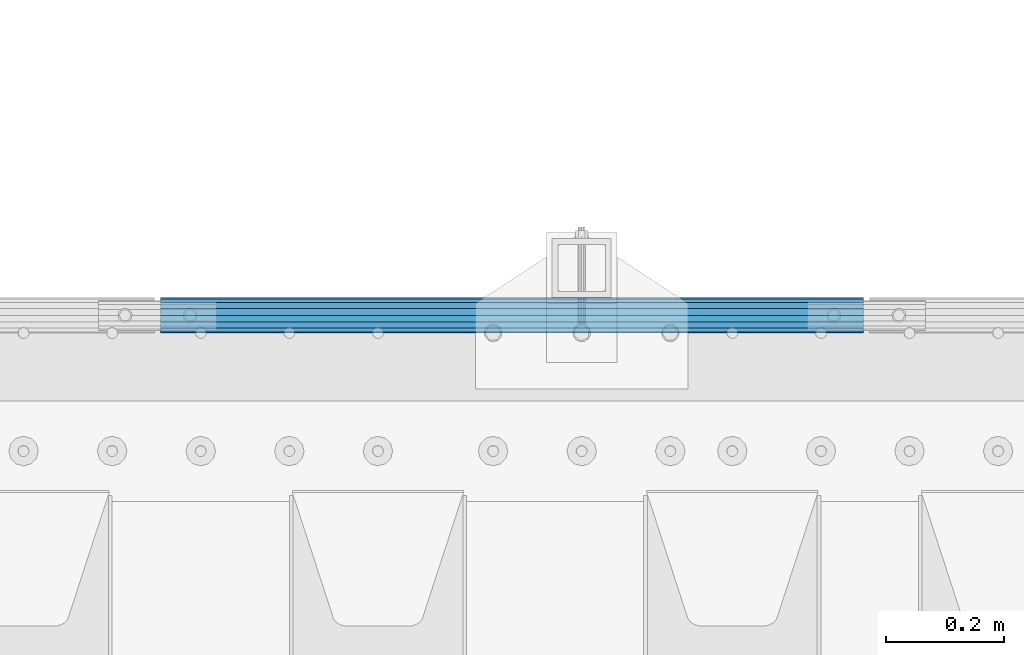
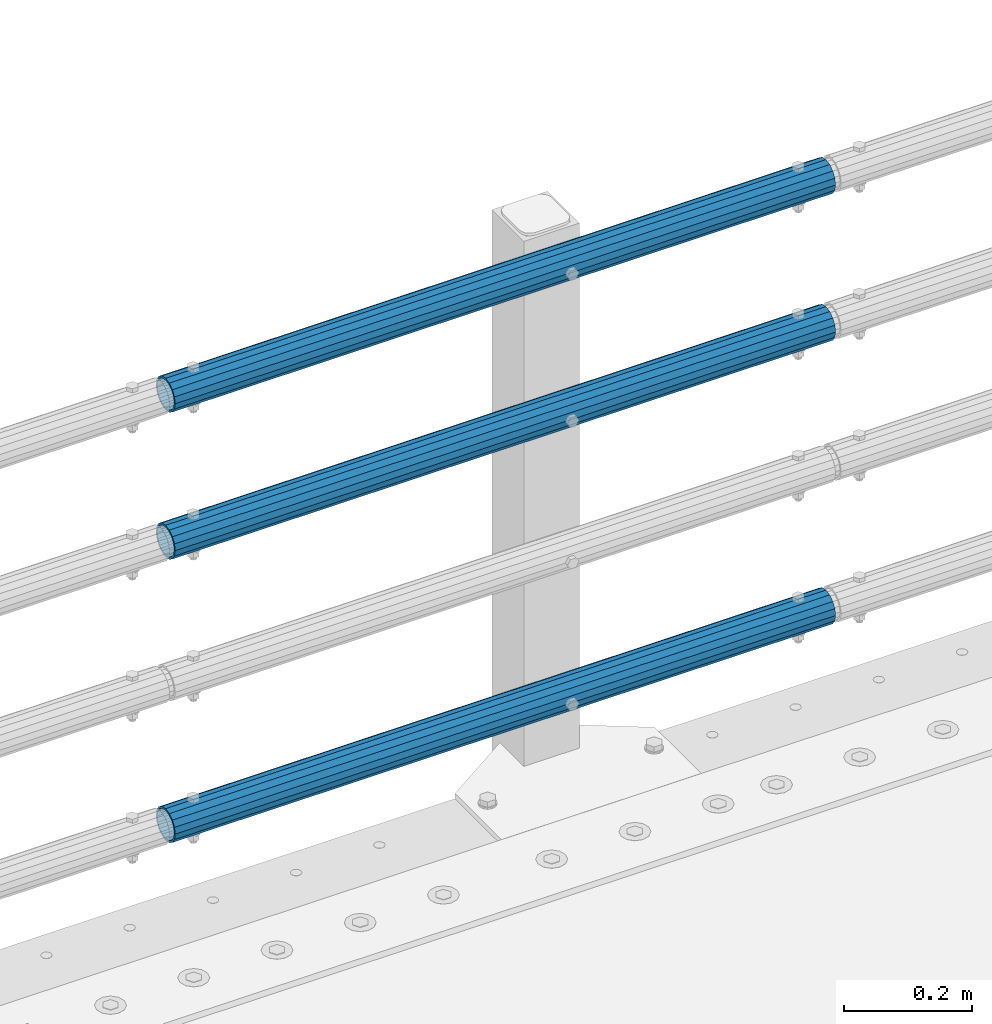
# One storey, part 130 of 247: 3 beams.
"""IFC2X3 building model written with IfcOpenShell, lengths in millimetres."""

from ifc_helpers import new_model, si_unit, frame, origin_with_axes, place, context, subcontext, project, spatial, faceted_brep, material, type_object, element, save


model = new_model("IFC2X3")

# Units and contexts
model_context = context("Model", 3, precision=1e-05, world=origin_with_axes())
body_context = subcontext(model_context, "Body", "Model", "MODEL_VIEW")
ifc_project = project(units=[si_unit("LENGTHUNIT", "METRE", prefix="MILLI"), si_unit("AREAUNIT", "SQUARE_METRE"), si_unit("VOLUMEUNIT", "CUBIC_METRE"), si_unit("MASSUNIT", "GRAM", prefix="KILO"), si_unit("TIMEUNIT", "SECOND"), si_unit("PLANEANGLEUNIT", "RADIAN"), si_unit("SOLIDANGLEUNIT", "STERADIAN"), si_unit("THERMODYNAMICTEMPERATUREUNIT", "DEGREE_CELSIUS"), si_unit("LUMINOUSINTENSITYUNIT", "LUMEN")], contexts=[model_context])

# Site, building, storey
site_placement = place(None, origin_with_axes())
site = spatial("IfcSite", under=ifc_project, at=site_placement, CompositionType="ELEMENT")
building_placement = place(site_placement, origin_with_axes())
building = spatial("IfcBuilding", under=site, at=building_placement, Name="Standard", CompositionType="ELEMENT")
storey_placement = place(building_placement, origin_with_axes())
storey = spatial("IfcBuildingStorey", under=building, at=storey_placement, Name="Undefined", CompositionType="ELEMENT", Elevation=0.0)

# Beams
ifc_material = material()
beam_type = type_object("IfcBeamType", PredefinedType="NOTDEFINED")
beam_1_placement = place(storey_placement, frame((14132.0000000001, 9129.8499999996, 149.549999999726), z_axis=(0.0, -0.999999999999548, -9.5100000000016e-07), x_axis=(1.0, 0.0, 0.0)))
element("IfcBeam", 1, at=beam_1_placement, inside=storey, type_object=beam_type, material=ifc_material, context=body_context, shape_type="Brep", body=[
    faceted_brep([(0.0, -26.5499999999993, 0.0), (0.0, -24.5290015881747, 10.1602451292931), (1190.0, -24.5290015881747, 10.1602451292929), (1190.0, -26.55, 0.0), (0.0, -18.7736850405036, 18.7736850405028), (1190.0, -18.7736850405028, 18.7736850405036), (0.0, -10.1602451292929, 24.5290015881747), (1190.0, -10.1602451292931, 24.5290015881747), (0.0, 0.0, 26.55), (1190.0, 0.0, 26.5499999999993), (0.0, 10.1602451292929, 24.5290015881747), (1190.0, 10.1602451292932, 24.5290015881747), (0.0, 18.7736850405036, 18.7736850405028), (1190.0, 18.7736850405029, 18.7736850405036), (0.0, 24.5290015881747, 10.1602451292931), (1190.0, 24.5290015881747, 10.1602451292929), (0.0, 26.5499999999993, 0.0), (1190.0, 26.55, 0.0), (0.0, 24.5290015881747, -10.1602451292931), (1190.0, 24.5290015881747, -10.1602451292929), (0.0, 18.7736850405036, -18.7736850405028), (1190.0, 18.7736850405028, -18.7736850405036), (0.0, 10.1602451292929, -24.5290015881747), (1190.0, 10.1602451292931, -24.5290015881747), (0.0, 0.0, -26.55), (1190.0, 0.0, -26.5499999999993), (0.0, -10.1602451292929, -24.5290015881747), (1190.0, -10.1602451292931, -24.5290015881747), (0.0, -18.7736850405036, -18.7736850405028), (1190.0, -18.7736850405028, -18.7736850405036), (0.0, -24.5290015881747, -10.1602451292931), (1190.0, -24.5290015881747, -10.1602451292929), (0.0, -30.1499999999996, 0.0), (0.0, -27.8549679052148, -11.5379054858076), (1190.0, -27.8549679052153, -11.5379054858076), (1190.0, -30.15, 0.0), (0.0, -21.3192694527743, -21.3192694527752), (1190.0, -21.3192694527744, -21.3192694527752), (0.0, -11.5379054858076, -27.8549679052157), (1190.0, -11.5379054858075, -27.8549679052157), (0.0, 0.0, -30.1499999999996), (1190.0, 0.0, -30.1499999999996), (0.0, 11.5379054858076, -27.8549679052157), (1190.0, 11.5379054858075, -27.8549679052157), (0.0, 21.3192694527743, -21.3192694527752), (1190.0, 21.3192694527744, -21.3192694527752), (0.0, 27.8549679052157, -11.5379054858076), (1190.0, 27.8549679052153, -11.5379054858076), (0.0, 30.1499999999996, 0.0), (1190.0, 30.15, 0.0), (0.0, 27.8549679052157, 11.5379054858076), (1190.0, 27.8549679052153, 11.5379054858076), (0.0, 21.3192694527743, 21.3192694527752), (1190.0, 21.3192694527744, 21.3192694527752), (0.0, 11.5379054858076, 27.8549679052157), (1190.0, 11.5379054858075, 27.8549679052157), (0.0, 0.0, 30.1499999999996), (1190.0, 0.0, 30.1499999999996), (0.0, -11.5379054858076, 27.8549679052157), (1190.0, -11.5379054858075, 27.8549679052157), (0.0, -21.3192694527743, 21.3192694527752), (1190.0, -21.3192694527744, 21.3192694527752), (0.0, -27.8549679052157, 11.5379054858076), (1190.0, -27.8549679052153, 11.5379054858076)], [[[0, 1, 2, 3]], [[1, 4, 5, 2]], [[4, 6, 7, 5]], [[6, 8, 9, 7]], [[8, 10, 11, 9]], [[10, 12, 13, 11]], [[12, 14, 15, 13]], [[14, 16, 17, 15]], [[16, 18, 19, 17]], [[18, 20, 21, 19]], [[20, 22, 23, 21]], [[22, 24, 25, 23]], [[24, 26, 27, 25]], [[26, 28, 29, 27]], [[28, 30, 31, 29]], [[30, 0, 3, 31]], [[32, 33, 34, 35]], [[33, 36, 37, 34]], [[36, 38, 39, 37]], [[38, 40, 41, 39]], [[40, 42, 43, 41]], [[42, 44, 45, 43]], [[44, 46, 47, 45]], [[46, 48, 49, 47]], [[48, 50, 51, 49]], [[50, 52, 53, 51]], [[52, 54, 55, 53]], [[54, 56, 57, 55]], [[56, 58, 59, 57]], [[58, 60, 61, 59]], [[60, 62, 63, 61]], [[62, 32, 35, 63]], [[37, 39, 41, 43, 45, 47, 49, 51, 53, 55, 57, 59, 61, 63, 35, 34], [5, 7, 9, 11, 13, 15, 17, 19, 21, 23, 25, 27, 29, 31, 3, 2]], [[62, 60, 58, 56, 54, 52, 50, 48, 46, 44, 42, 40, 38, 36, 33, 32], [30, 28, 26, 24, 22, 20, 18, 16, 14, 12, 10, 8, 6, 4, 1, 0]]]),
])
beam_2_placement = place(storey_placement, frame((14132.0000000001, 9129.8499999996, 969.549999999726), z_axis=(0.0, -0.999999999999548, -9.5100000000016e-07), x_axis=(1.0, 0.0, 0.0)))
element("IfcBeam", 2, at=beam_2_placement, inside=storey, type_object=beam_type, material=ifc_material, context=body_context, shape_type="Brep", body=[
    faceted_brep([(0.0, -26.5499999999993, 0.0), (0.0, -24.5290015881747, 10.1602451292931), (1190.0, -24.5290015881747, 10.1602451292929), (1190.0, -26.55, 0.0), (0.0, -18.7736850405036, 18.7736850405028), (1190.0, -18.7736850405028, 18.7736850405036), (0.0, -10.1602451292929, 24.5290015881747), (1190.0, -10.1602451292931, 24.5290015881747), (0.0, 0.0, 26.55), (1190.0, 0.0, 26.5499999999993), (0.0, 10.1602451292929, 24.5290015881747), (1190.0, 10.1602451292932, 24.5290015881747), (0.0, 18.7736850405036, 18.7736850405028), (1190.0, 18.7736850405029, 18.7736850405036), (0.0, 24.5290015881747, 10.1602451292931), (1190.0, 24.5290015881747, 10.1602451292929), (0.0, 26.5499999999993, 0.0), (1190.0, 26.55, 0.0), (0.0, 24.5290015881747, -10.1602451292931), (1190.0, 24.5290015881747, -10.1602451292929), (0.0, 18.7736850405036, -18.7736850405028), (1190.0, 18.7736850405028, -18.7736850405036), (0.0, 10.1602451292929, -24.5290015881747), (1190.0, 10.1602451292931, -24.5290015881747), (0.0, 0.0, -26.55), (1190.0, 0.0, -26.5499999999993), (0.0, -10.1602451292929, -24.5290015881747), (1190.0, -10.1602451292931, -24.5290015881747), (0.0, -18.7736850405036, -18.7736850405028), (1190.0, -18.7736850405028, -18.7736850405036), (0.0, -24.5290015881747, -10.1602451292931), (1190.0, -24.5290015881747, -10.1602451292929), (0.0, -30.1499999999996, 0.0), (0.0, -27.8549679052148, -11.5379054858076), (1190.0, -27.8549679052153, -11.5379054858076), (1190.0, -30.15, 0.0), (0.0, -21.3192694527743, -21.3192694527752), (1190.0, -21.3192694527744, -21.3192694527752), (0.0, -11.5379054858076, -27.8549679052157), (1190.0, -11.5379054858075, -27.8549679052157), (0.0, 0.0, -30.1499999999996), (1190.0, 0.0, -30.1499999999996), (0.0, 11.5379054858076, -27.8549679052157), (1190.0, 11.5379054858075, -27.8549679052157), (0.0, 21.3192694527743, -21.3192694527752), (1190.0, 21.3192694527744, -21.3192694527752), (0.0, 27.8549679052157, -11.5379054858076), (1190.0, 27.8549679052153, -11.5379054858076), (0.0, 30.1499999999996, 0.0), (1190.0, 30.15, 0.0), (0.0, 27.8549679052157, 11.5379054858076), (1190.0, 27.8549679052153, 11.5379054858076), (0.0, 21.3192694527743, 21.3192694527752), (1190.0, 21.3192694527744, 21.3192694527752), (0.0, 11.5379054858076, 27.8549679052157), (1190.0, 11.5379054858075, 27.8549679052157), (0.0, 0.0, 30.1499999999996), (1190.0, 0.0, 30.1499999999996), (0.0, -11.5379054858076, 27.8549679052157), (1190.0, -11.5379054858075, 27.8549679052157), (0.0, -21.3192694527743, 21.3192694527752), (1190.0, -21.3192694527744, 21.3192694527752), (0.0, -27.8549679052157, 11.5379054858076), (1190.0, -27.8549679052153, 11.5379054858076)], [[[0, 1, 2, 3]], [[1, 4, 5, 2]], [[4, 6, 7, 5]], [[6, 8, 9, 7]], [[8, 10, 11, 9]], [[10, 12, 13, 11]], [[12, 14, 15, 13]], [[14, 16, 17, 15]], [[16, 18, 19, 17]], [[18, 20, 21, 19]], [[20, 22, 23, 21]], [[22, 24, 25, 23]], [[24, 26, 27, 25]], [[26, 28, 29, 27]], [[28, 30, 31, 29]], [[30, 0, 3, 31]], [[32, 33, 34, 35]], [[33, 36, 37, 34]], [[36, 38, 39, 37]], [[38, 40, 41, 39]], [[40, 42, 43, 41]], [[42, 44, 45, 43]], [[44, 46, 47, 45]], [[46, 48, 49, 47]], [[48, 50, 51, 49]], [[50, 52, 53, 51]], [[52, 54, 55, 53]], [[54, 56, 57, 55]], [[56, 58, 59, 57]], [[58, 60, 61, 59]], [[60, 62, 63, 61]], [[62, 32, 35, 63]], [[37, 39, 41, 43, 45, 47, 49, 51, 53, 55, 57, 59, 61, 63, 35, 34], [5, 7, 9, 11, 13, 15, 17, 19, 21, 23, 25, 27, 29, 31, 3, 2]], [[62, 60, 58, 56, 54, 52, 50, 48, 46, 44, 42, 40, 38, 36, 33, 32], [30, 28, 26, 24, 22, 20, 18, 16, 14, 12, 10, 8, 6, 4, 1, 0]]]),
])
beam_3_placement = place(storey_placement, frame((14132.0000000001, 9129.8499999996, 689.549999999726), z_axis=(0.0, -0.999999999999548, -9.5100000000016e-07), x_axis=(1.0, 0.0, 0.0)))
element("IfcBeam", 3, at=beam_3_placement, inside=storey, type_object=beam_type, material=ifc_material, context=body_context, shape_type="Brep", body=[
    faceted_brep([(0.0, -26.5499999999993, 0.0), (0.0, -24.5290015881747, 10.1602451292931), (1190.0, -24.5290015881747, 10.1602451292929), (1190.0, -26.55, 0.0), (0.0, -18.7736850405036, 18.7736850405028), (1190.0, -18.7736850405028, 18.7736850405036), (0.0, -10.1602451292929, 24.5290015881747), (1190.0, -10.1602451292931, 24.5290015881747), (0.0, 0.0, 26.55), (1190.0, 0.0, 26.5499999999993), (0.0, 10.1602451292929, 24.5290015881747), (1190.0, 10.1602451292932, 24.5290015881747), (0.0, 18.7736850405036, 18.7736850405028), (1190.0, 18.7736850405029, 18.7736850405036), (0.0, 24.5290015881747, 10.1602451292931), (1190.0, 24.5290015881747, 10.1602451292929), (0.0, 26.5499999999993, 0.0), (1190.0, 26.55, 0.0), (0.0, 24.5290015881747, -10.1602451292931), (1190.0, 24.5290015881747, -10.1602451292929), (0.0, 18.7736850405036, -18.7736850405028), (1190.0, 18.7736850405028, -18.7736850405036), (0.0, 10.1602451292929, -24.5290015881747), (1190.0, 10.1602451292931, -24.5290015881747), (0.0, 0.0, -26.55), (1190.0, 0.0, -26.5499999999993), (0.0, -10.1602451292929, -24.5290015881747), (1190.0, -10.1602451292931, -24.5290015881747), (0.0, -18.7736850405036, -18.7736850405028), (1190.0, -18.7736850405028, -18.7736850405036), (0.0, -24.5290015881747, -10.1602451292931), (1190.0, -24.5290015881747, -10.1602451292929), (0.0, -30.1499999999996, 0.0), (0.0, -27.8549679052148, -11.5379054858076), (1190.0, -27.8549679052153, -11.5379054858076), (1190.0, -30.15, 0.0), (0.0, -21.3192694527743, -21.3192694527752), (1190.0, -21.3192694527744, -21.3192694527752), (0.0, -11.5379054858076, -27.8549679052157), (1190.0, -11.5379054858075, -27.8549679052157), (0.0, 0.0, -30.1499999999996), (1190.0, 0.0, -30.1499999999996), (0.0, 11.5379054858076, -27.8549679052157), (1190.0, 11.5379054858075, -27.8549679052157), (0.0, 21.3192694527743, -21.3192694527752), (1190.0, 21.3192694527744, -21.3192694527752), (0.0, 27.8549679052157, -11.5379054858076), (1190.0, 27.8549679052153, -11.5379054858076), (0.0, 30.1499999999996, 0.0), (1190.0, 30.15, 0.0), (0.0, 27.8549679052157, 11.5379054858076), (1190.0, 27.8549679052153, 11.5379054858076), (0.0, 21.3192694527743, 21.3192694527752), (1190.0, 21.3192694527744, 21.3192694527752), (0.0, 11.5379054858076, 27.8549679052157), (1190.0, 11.5379054858075, 27.8549679052157), (0.0, 0.0, 30.1499999999996), (1190.0, 0.0, 30.1499999999996), (0.0, -11.5379054858076, 27.8549679052157), (1190.0, -11.5379054858075, 27.8549679052157), (0.0, -21.3192694527743, 21.3192694527752), (1190.0, -21.3192694527744, 21.3192694527752), (0.0, -27.8549679052157, 11.5379054858076), (1190.0, -27.8549679052153, 11.5379054858076)], [[[0, 1, 2, 3]], [[1, 4, 5, 2]], [[4, 6, 7, 5]], [[6, 8, 9, 7]], [[8, 10, 11, 9]], [[10, 12, 13, 11]], [[12, 14, 15, 13]], [[14, 16, 17, 15]], [[16, 18, 19, 17]], [[18, 20, 21, 19]], [[20, 22, 23, 21]], [[22, 24, 25, 23]], [[24, 26, 27, 25]], [[26, 28, 29, 27]], [[28, 30, 31, 29]], [[30, 0, 3, 31]], [[32, 33, 34, 35]], [[33, 36, 37, 34]], [[36, 38, 39, 37]], [[38, 40, 41, 39]], [[40, 42, 43, 41]], [[42, 44, 45, 43]], [[44, 46, 47, 45]], [[46, 48, 49, 47]], [[48, 50, 51, 49]], [[50, 52, 53, 51]], [[52, 54, 55, 53]], [[54, 56, 57, 55]], [[56, 58, 59, 57]], [[58, 60, 61, 59]], [[60, 62, 63, 61]], [[62, 32, 35, 63]], [[37, 39, 41, 43, 45, 47, 49, 51, 53, 55, 57, 59, 61, 63, 35, 34], [5, 7, 9, 11, 13, 15, 17, 19, 21, 23, 25, 27, 29, 31, 3, 2]], [[62, 60, 58, 56, 54, 52, 50, 48, 46, 44, 42, 40, 38, 36, 33, 32], [30, 28, 26, 24, 22, 20, 18, 16, 14, 12, 10, 8, 6, 4, 1, 0]]]),
])

save(model, "model.ifc")
